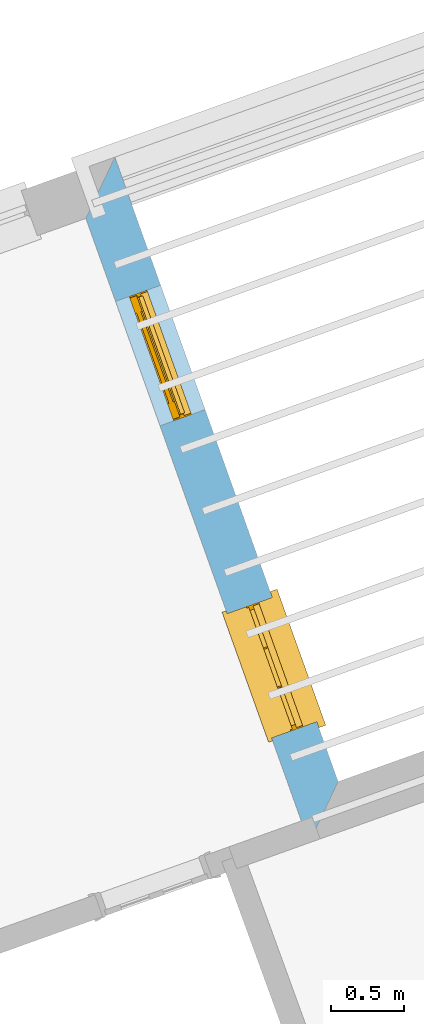
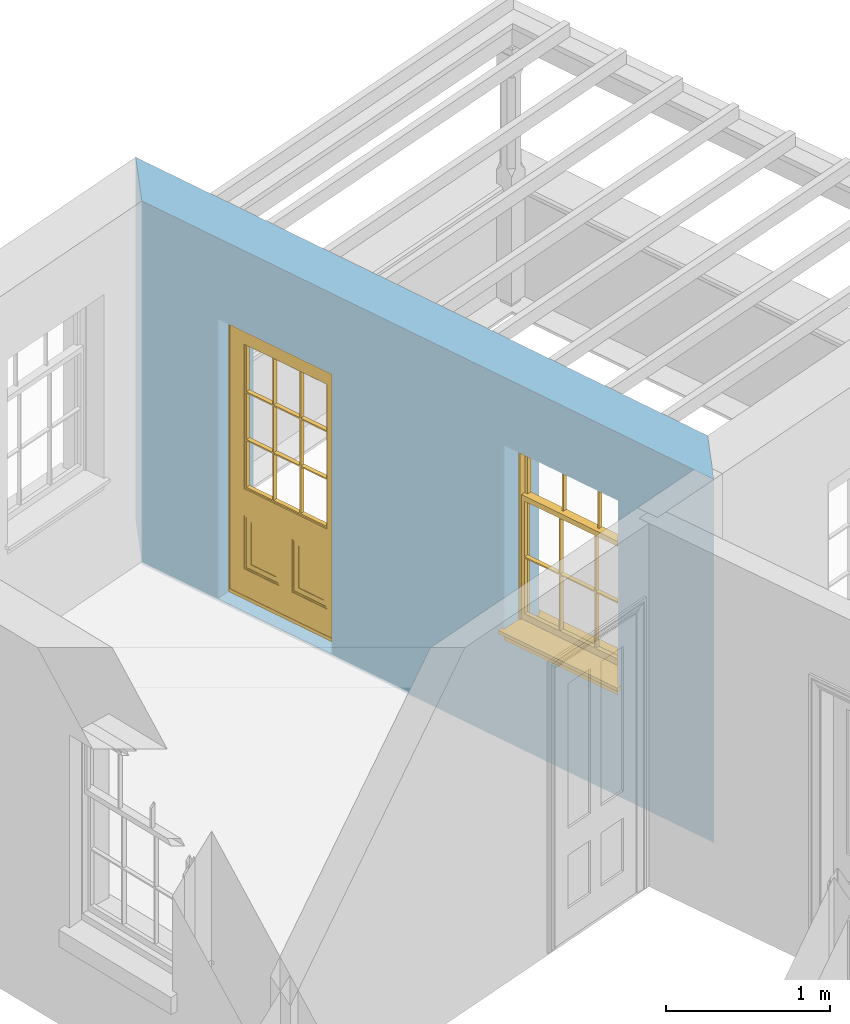
# One storey, part 9 of 12: 1 door, 1 window, 2 openings, plus 1 element that does not belong to this part.
"""IFC2X3 building model written with IfcOpenShell, lengths in metres."""

from ifc_helpers import new_model, si_unit, frame, origin, place, context, subcontext, project, spatial, polyline, outline, extrude, faceted_brep, material, layer, layer_set, layer_usage, element, fill, save


model = new_model("IFC2X3")

# Units and contexts
model_context = context("Model", 3, world=origin())
body_context = subcontext(model_context, "Body", "Model", "MODEL_VIEW")
ifc_project = project(units=[si_unit("PLANEANGLEUNIT", "RADIAN"), si_unit("MASSUNIT", "GRAM", prefix="KILO"), si_unit("FORCEUNIT", "NEWTON", prefix="KILO"), si_unit("LENGTHUNIT", "METRE")], contexts=[model_context])

# Site, building, storey
site_placement = place(None, origin())
site = spatial("IfcSite", under=ifc_project, at=site_placement, CompositionType="ELEMENT")
building_placement = place(None, origin())
building = spatial("IfcBuilding", under=site, at=building_placement, Name="Building plot-12", CompositionType="ELEMENT")
storey_placement = place(None, frame((0.0, 0.0, 6.45)))
storey = spatial("IfcBuildingStorey", under=building, at=storey_placement, Name="Floor 1", CompositionType="ELEMENT", Elevation=6.45)

# Wall, openings, window, door
ifc_material = material(Name="Masonry")
ifc_layer = layer(ifc_material, 0.33, ventilated=False)
ifc_layer_set = layer_set([ifc_layer], Name="My Wall")
ifc_layer_usage = layer_usage(ifc_layer_set, "AXIS2", "NEGATIVE", 0.08)
wall_placement = place(storey_placement, origin())
wall = element("IfcWallStandardCase", 1, at=wall_placement, inside=storey, material=ifc_layer_usage, Name="exterior", context=body_context, shape_type="SweptSolid", body=[
    extrude(outline(polyline([(57.8909410000931, 39.8252226026139), (58.0905645178046, 40.247064339734), (56.5533203704707, 44.5461889943348), (56.3536968527592, 44.1243472572147), (57.8909410000931, 39.8252226026139)])), origin(), (0.0, 0.0, 1.0), 2.7),
])
opening_1_placement = place(storey_placement, frame((0.0, 0.0, 0.75)))
opening_1 = element("IfcOpeningElement", 2, at=opening_1_placement, cuts=wall, Name="Opening", ObjectType="Opening", context=body_context, shape_type="SweptSolid", body=[
    extrude(outline(polyline([(57.9436229426122, 40.6580076175414), (57.6372311552457, 41.514876377991), (57.3264985278299, 41.4037672682867), (57.6328903151964, 40.5468985078371), (57.9436229426122, 40.6580076175414)])), origin(), (0.0, 0.0, 1.0), 1.445),
])
opening_2_placement = place(storey_placement, frame((0.0, 0.0, 0.0199999999999996)))
opening_2 = element("IfcOpeningElement", 3, at=opening_2_placement, cuts=wall, Name="Opening", ObjectType="Opening", context=body_context, shape_type="SweptSolid", body=[
    extrude(outline(polyline([(57.1750008689452, 42.8075699448418), (56.8686090815788, 43.6644387052913), (56.557876454163, 43.553329595587), (56.8642682415294, 42.6964608351374), (57.1750008689452, 42.8075699448418)])), origin(), (0.0, 0.0, 1.0), 2.08),
])
window_placement = place(storey_placement, frame((57.7082194369942, 40.5738340495836, 0.75), z_axis=(0.0, 0.0, 1.0), x_axis=(-0.306391787366465, 0.856868760449572, 0.0)))
window = element("IfcWindow", 4, at=window_placement, inside=storey, Name="bedroom outside window", OverallHeight=1.445, OverallWidth=0.91, context=body_context, shape_type="Brep", held_by="IfcProductRepresentation", body=[
    faceted_brep([(0.876875, -0.105, 0.999097), (0.876875, -0.105, 1.411875), (0.9, -0.105, 1.435), (0.033125, -0.105, 1.411875), (0.033125, -0.105, 0.999097), (0.01, -0.105, 1.435), (0.033125, -0.135, 1.411875), (0.01, -0.135, 1.435), (0.033125, -0.135, 0.999097), (0.876875, -0.135, 1.411875), (0.876875, -0.135, 0.999097), (0.9, -0.135, 1.435), (0.033125, -0.105, 0.960972), (0.01, -0.105, 0.960972), (0.033125, -0.105, 0.548195), (0.876875, -0.105, 0.960972), (0.876875, -0.105, 0.548195), (0.9, -0.105, 0.960972), (0.876875, -0.105, 0.538195), (0.876875, -0.105, 0.125417), (0.9, -0.105, 0.077167), (0.033125, -0.105, 0.125417), (0.033125, -0.105, 0.538195), (0.01, -0.105, 0.077167), (0.9, -0.135, 0.960972), (0.01, -0.135, 0.960972), (-0.0425, -0.25, 0.01), (-0.0425, -0.3, 0.001667), (0.0, -0.25, 0.01), (0.9525, -0.25, 0.01), (0.91, -0.25, 0.01), (0.9525, -0.3, 0.001667), (-0.02, 0.08, 0.077167), (0.0, 0.08, 0.077167), (-0.02, 0.11, 0.077167), (0.0, -0.06, 0.077167), (0.01, -0.06, 0.077167), (0.91, -0.06, 0.077167), (0.91, 0.08, 0.077167), (0.9, -0.06, 0.077167), (0.93, 0.08, 0.077167), (0.93, 0.11, 0.077167), (0.01, -0.105, 0.999097), (0.01, -0.075, 0.999097), (0.9, -0.105, 0.999097), (0.9, -0.075, 0.999097), (0.876875, -0.075, 0.125417), (0.876875, -0.075, 0.538195), (0.9, -0.075, 0.077167), (0.876875, -0.075, 0.548195), (0.876875, -0.075, 0.960972), (0.033125, -0.075, 0.125417), (0.01, -0.075, 0.077167), (0.033125, -0.075, 0.538195), (0.033125, -0.075, 0.960972), (0.033125, -0.075, 0.548195), (-0.02, 0.08, 0.052167), (-0.02, 0.11, 0.052167), (0.93, 0.11, 0.052167), (0.93, 0.08, 0.052167), (0.91, 0.08, 0.052167), (0.0, 0.08, 0.052167), (0.91, -0.15, 0.026667), (0.0, -0.15, 0.026667), (-0.0425, -0.3, -0.123333), (0.9525, -0.3, -0.123333), (-0.0425, -0.25, -0.123333), (0.9525, -0.25, -0.123333), (0.01, -0.06, 1.435), (0.9, -0.06, 1.435), (0.0, -0.06, 1.445), (0.91, -0.06, 1.445), (0.01, -0.15, 0.077167), (0.9, -0.15, 0.077167), (0.592292, -0.105, 0.125417), (0.592292, -0.075, 0.125417), (0.317708, -0.075, 0.125417), (0.317708, -0.105, 0.125417), (0.592292, -0.105, 0.548195), (0.317708, -0.105, 0.548195), (0.317708, -0.105, 0.538195), (0.592292, -0.105, 0.538195), (0.592292, -0.075, 0.548195), (0.317708, -0.075, 0.548195), (0.602292, -0.075, 0.548195), (0.602292, -0.105, 0.548195), (0.317708, -0.075, 0.538195), (0.307708, -0.075, 0.125417), (0.307708, -0.075, 0.538195), (0.602292, -0.075, 0.538195), (0.602292, -0.075, 0.125417), (0.592292, -0.075, 0.538195), (0.307708, -0.075, 0.548195), (0.317708, -0.075, 0.960972), (0.307708, -0.075, 0.960972), (0.602292, -0.075, 0.960972), (0.592292, -0.075, 0.960972), (0.307708, -0.105, 0.538195), (0.307708, -0.105, 0.125417), (0.307708, -0.105, 0.548195), (0.307708, -0.105, 0.960972), (0.592292, -0.105, 0.960972), (0.317708, -0.105, 0.960972), (0.602292, -0.105, 0.960972), (0.602292, -0.105, 0.538195), (0.602292, -0.105, 0.125417), (0.317708, -0.135, 1.411875), (0.307708, -0.135, 1.411875), (0.307708, -0.135, 0.999097), (0.317708, -0.135, 0.999097), (0.602292, -0.135, 1.411875), (0.592292, -0.135, 1.411875), (0.592292, -0.135, 0.999097), (0.602292, -0.135, 0.999097), (0.317708, -0.105, 0.999097), (0.307708, -0.105, 0.999097), (0.307708, -0.105, 1.411875), (0.317708, -0.105, 1.411875), (0.602292, -0.105, 0.999097), (0.592292, -0.105, 0.999097), (0.592292, -0.105, 1.411875), (0.602292, -0.105, 1.411875), (0.91, -0.15, 1.445), (0.9, -0.15, 1.435), (0.01, -0.15, 1.435), (0.0, -0.15, 1.445), (0.91, -0.25, 0.0), (0.0, -0.25, 0.0), (0.91, 0.08, 0.0), (0.0, 0.08, 0.0)], [[[0, 1, 2]], [[3, 4, 5]], [[6, 7, 8]], [[9, 10, 11]], [[12, 13, 14]], [[15, 16, 17]], [[18, 19, 20]], [[21, 22, 23]], [[24, 15, 17]], [[13, 12, 25]], [[26, 27, 28]], [[29, 30, 31]], [[32, 33, 34]], [[35, 36, 33]], [[37, 38, 39]], [[40, 41, 38]], [[42, 4, 43]], [[44, 45, 0]], [[46, 47, 48]], [[49, 50, 45]], [[51, 52, 53]], [[54, 55, 43]], [[38, 33, 36, 39]], [[41, 34, 33, 38]], [[56, 32, 34, 57]], [[57, 34, 41, 58]], [[58, 41, 40, 59]], [[57, 58, 60, 61]], [[52, 48, 39, 36]], [[62, 63, 28, 30]], [[27, 31, 30, 28]], [[27, 64, 65, 31]], [[66, 67, 65, 64]], [[2, 5, 68, 69]], [[68, 70, 71, 69]], [[20, 23, 72, 73]], [[73, 72, 63, 62]], [[74, 75, 76, 77]], [[78, 79, 80, 81]], [[78, 82, 83, 79]], [[16, 49, 84, 85]], [[86, 76, 87, 88]], [[89, 90, 75, 91]], [[92, 88, 53, 55]], [[82, 91, 86, 83]], [[93, 83, 92, 94]], [[95, 84, 82, 96]], [[89, 84, 49, 47]], [[97, 88, 87, 98]], [[22, 53, 88, 97]], [[81, 91, 75, 74]], [[80, 86, 91, 81]], [[77, 76, 86, 80]], [[99, 92, 55, 14]], [[100, 94, 92, 99]], [[101, 96, 82, 78]], [[79, 83, 93, 102]], [[85, 84, 95, 103]], [[104, 89, 47, 18]], [[105, 90, 89, 104]], [[104, 18, 16, 85]], [[80, 97, 98, 77]], [[104, 81, 74, 105]], [[103, 101, 78, 85]], [[99, 14, 22, 97]], [[102, 100, 99, 79]], [[106, 107, 108, 109]], [[110, 111, 112, 113]], [[114, 115, 116, 117]], [[118, 119, 120, 121]], [[107, 116, 115, 108]], [[111, 120, 119, 112]], [[109, 114, 117, 106]], [[113, 118, 121, 110]], [[85, 78, 81, 104]], [[84, 89, 91, 82]], [[83, 86, 88, 92]], [[79, 99, 97, 80]], [[109, 112, 119, 114]], [[102, 93, 96, 101]], [[106, 117, 120, 111]], [[98, 87, 51, 21]], [[6, 3, 116, 107]], [[110, 121, 1, 9]], [[19, 46, 90, 105]], [[26, 66, 64, 27]], [[29, 31, 65, 67]], [[25, 24, 112, 109]], [[11, 7, 106, 111]], [[75, 48, 52, 76]], [[43, 45, 96, 93]], [[45, 43, 114, 119]], [[5, 2, 120, 117]], [[24, 25, 102, 101]], [[42, 5, 4]], [[2, 44, 0]], [[49, 45, 48, 47]], [[52, 43, 55, 53]], [[14, 13, 23, 22]], [[20, 17, 16, 18]], [[24, 11, 10]], [[25, 8, 7]], [[8, 4, 3, 6]], [[9, 1, 0, 10]], [[15, 50, 49, 16]], [[18, 47, 46, 19]], [[21, 51, 53, 22]], [[14, 55, 54, 12]], [[44, 2, 69, 45]], [[68, 5, 42, 43]], [[36, 35, 70, 68]], [[39, 69, 71, 37]], [[62, 122, 123, 73]], [[63, 72, 124, 125]], [[8, 108, 115, 4]], [[113, 10, 0, 118]], [[94, 100, 12, 54]], [[17, 20, 73, 24]], [[72, 23, 13, 25]], [[52, 36, 68, 43]], [[69, 39, 48, 45]], [[11, 24, 73, 123]], [[7, 124, 72, 25]], [[23, 77, 98]], [[98, 21, 23]], [[105, 74, 20]], [[20, 19, 105]], [[20, 74, 77, 23]], [[113, 112, 24]], [[24, 10, 113]], [[25, 109, 108]], [[108, 8, 25]], [[110, 9, 11]], [[11, 111, 110]], [[7, 6, 107]], [[107, 106, 7]], [[5, 117, 116]], [[116, 3, 5]], [[121, 120, 2]], [[2, 1, 121]], [[11, 123, 124, 7]], [[122, 125, 124, 123]], [[43, 93, 94]], [[94, 54, 43]], [[96, 45, 95]], [[50, 95, 45]], [[15, 103, 95, 50]], [[48, 75, 90]], [[90, 46, 48]], [[87, 76, 52]], [[52, 51, 87]], [[103, 15, 24]], [[24, 101, 103]], [[100, 102, 25]], [[25, 12, 100]], [[115, 114, 43]], [[43, 4, 115]], [[118, 0, 45]], [[45, 119, 118]], [[71, 70, 125, 122]], [[70, 35, 63, 125]], [[122, 62, 37, 71]], [[126, 67, 66, 127]], [[60, 58, 59]], [[38, 60, 59, 40]], [[61, 56, 57]], [[32, 56, 61, 33]], [[61, 60, 128, 129]], [[62, 60, 38, 37]], [[126, 128, 60, 62]], [[33, 61, 63, 35]], [[61, 129, 127, 63]], [[128, 126, 127, 129]], [[28, 127, 66, 26]], [[63, 127, 28]], [[29, 67, 126, 30]], [[30, 126, 62]]]),
])
fill(opening_1, window)
door_placement = place(storey_placement, frame((56.9395973633272, 42.7233963768839, 0.0199999999999996), z_axis=(0.0, 0.0, 1.0), x_axis=(-0.306391787366465, 0.856868760449572, 0.0)))
door = element("IfcDoor", 5, at=door_placement, inside=storey, Name="bedroom outside door", OverallHeight=2.08, OverallWidth=0.91, context=body_context, shape_type="Brep", held_by="IfcProductRepresentation", body=[
    faceted_brep([(0.545, -0.055, 0.265), (0.745, -0.055, 0.265), (0.745, -0.05, 0.265), (0.545, -0.05, 0.265), (0.745, -0.05, 0.58), (0.545, -0.05, 0.58), (0.545, -0.055, 0.58), (0.515, -0.06, 0.235), (0.775, -0.06, 0.235), (0.745, -0.055, 0.58), (0.515, -0.06, 0.61), (0.515, -0.065, 0.235), (0.775, -0.065, 0.235), (0.775, -0.06, 0.61), (0.515, -0.065, 0.61), (0.785, -0.065, 0.225), (0.505, -0.065, 0.225), (0.775, -0.065, 0.61), (0.505, -0.065, 0.62), (0.785, -0.065, 0.62), (0.505, -0.07, 0.225), (0.785, -0.07, 0.225), (0.505, -0.07, 0.62), (0.785, -0.07, 0.62), (0.883, -0.07, 0.075), (0.898, -0.07, 0.075), (0.405, -0.07, 0.62), (0.405, -0.07, 0.225), (0.027, -0.07, 0.075), (0.785, -0.07, 0.82), (0.125, -0.07, 0.82), (0.405, -0.065, 0.62), (0.405, -0.065, 0.225), (0.898, -0.07, 2.068), (0.027, -0.08, 0.075), (0.883, -0.08, 0.075), (0.125, -0.07, 0.225), (0.012, -0.07, 0.075), (0.785, -0.06, 0.82), (0.125, -0.06, 0.82), (0.125, -0.07, 0.62), (0.125, -0.065, 0.62), (0.395, -0.065, 0.61), (0.395, -0.065, 0.235), (0.125, -0.065, 0.225), (0.785, -0.07, 1.895), (0.027, -0.11, 0.045), (0.883, -0.11, 0.045), (0.558333, -0.06, 0.83), (0.351667, -0.06, 0.83), (0.125, -0.07, 1.895), (0.125, -0.06, 1.895), (0.785, -0.06, 1.895), (0.012, -0.07, 2.068), (0.135, -0.065, 0.61), (0.395, -0.06, 0.61), (0.395, -0.06, 0.235), (0.135, -0.065, 0.235), (0.027, -0.11, 0.027), (0.883, -0.11, 0.027), (0.568333, -0.06, 0.83), (0.558333, -0.03, 0.83), (0.351667, -0.03, 0.83), (0.341667, -0.06, 0.83), (0.135, -0.06, 1.185), (0.135, -0.06, 1.53), (0.775, -0.06, 1.53), (0.775, -0.06, 1.185), (0.135, -0.06, 0.61), (0.365, -0.055, 0.58), (0.365, -0.055, 0.265), (0.135, -0.06, 0.235), (0.568333, -0.06, 1.175), (0.558333, -0.06, 1.175), (0.775, -0.06, 0.83), (0.558333, -0.03, 1.175), (0.785, -0.03, 0.82), (0.125, -0.03, 0.82), (0.351667, -0.03, 1.175), (0.351667, -0.06, 1.175), (0.341667, -0.06, 1.175), (0.135, -0.06, 0.83), (0.135, -0.06, 1.175), (0.135, -0.03, 1.185), (0.135, -0.03, 1.53), (0.135, -0.06, 1.54), (0.351667, -0.06, 1.885), (0.558333, -0.06, 1.885), (0.775, -0.03, 1.53), (0.775, -0.03, 1.185), (0.775, -0.06, 1.175), (0.775, -0.06, 1.54), (0.165, -0.055, 0.58), (0.365, -0.05, 0.58), (0.365, -0.05, 0.265), (0.165, -0.055, 0.265), (0.568333, -0.03, 0.83), (0.568333, -0.03, 1.175), (0.568333, -0.06, 1.185), (0.558333, -0.06, 1.185), (0.775, -0.03, 0.83), (0.785, -0.02, 0.82), (0.125, -0.02, 0.82), (0.341667, -0.03, 0.83), (0.341667, -0.03, 1.175), (0.351667, -0.06, 1.185), (0.341667, -0.06, 1.185), (0.135, -0.03, 0.83), (0.341667, -0.03, 1.185), (0.125, -0.03, 1.895), (0.341667, -0.03, 1.53), (0.341667, -0.06, 1.53), (0.135, -0.06, 1.885), (0.341667, -0.06, 1.54), (0.341667, -0.06, 1.885), (0.558333, -0.03, 1.885), (0.351667, -0.03, 1.885), (0.568333, -0.06, 1.885), (0.785, -0.03, 1.895), (0.568333, -0.03, 1.185), (0.568333, -0.06, 1.53), (0.568333, -0.03, 1.53), (0.568333, -0.06, 1.54), (0.775, -0.06, 1.885), (0.165, -0.05, 0.58), (0.165, -0.05, 0.265), (0.775, -0.03, 1.175), (0.558333, -0.06, 1.53), (0.351667, -0.03, 1.185), (0.558333, -0.03, 1.185), (0.505, -0.02, 0.62), (0.405, -0.02, 0.62), (0.125, -0.02, 1.895), (0.785, -0.02, 1.895), (0.351667, -0.06, 1.53), (0.135, -0.03, 1.175), (0.135, -0.03, 1.54), (0.341667, -0.03, 1.54), (0.135, -0.03, 1.885), (0.351667, -0.06, 1.54), (0.558333, -0.03, 1.54), (0.558333, -0.06, 1.54), (0.351667, -0.03, 1.54), (0.775, -0.03, 1.54), (0.568333, -0.03, 1.54), (0.775, -0.03, 1.885), (0.558333, -0.03, 1.53), (0.405, -0.02, 0.225), (0.505, -0.02, 0.225), (0.125, -0.02, 0.62), (0.785, -0.02, 0.62), (0.012, -0.02, 2.068), (0.898, -0.02, 2.068), (0.351667, -0.03, 1.53), (0.341667, -0.03, 1.885), (0.568333, -0.03, 1.885), (0.405, -0.025, 0.225), (0.405, -0.025, 0.62), (0.505, -0.025, 0.62), (0.505, -0.025, 0.225), (0.898, -0.02, 0.027), (0.012, -0.02, 0.027), (0.125, -0.025, 0.62), (0.785, -0.025, 0.62), (0.395, -0.025, 0.235), (0.395, -0.025, 0.61), (0.125, -0.02, 0.225), (0.125, -0.025, 0.225), (0.515, -0.025, 0.61), (0.515, -0.025, 0.235), (0.785, -0.02, 0.225), (0.785, -0.025, 0.225), (0.135, -0.025, 0.61), (0.775, -0.025, 0.61), (0.135, -0.025, 0.235), (0.395, -0.03, 0.235), (0.395, -0.03, 0.61), (0.515, -0.03, 0.61), (0.515, -0.03, 0.235), (0.775, -0.025, 0.235), (0.135, -0.03, 0.61), (0.775, -0.03, 0.61), (0.135, -0.03, 0.235), (0.365, -0.035, 0.265), (0.365, -0.035, 0.58), (0.545, -0.035, 0.58), (0.545, -0.035, 0.265), (0.775, -0.03, 0.235), (0.165, -0.035, 0.58), (0.745, -0.035, 0.58), (0.165, -0.035, 0.265), (0.365, -0.04, 0.58), (0.365, -0.04, 0.265), (0.545, -0.04, 0.58), (0.545, -0.04, 0.265), (0.745, -0.035, 0.265), (0.165, -0.04, 0.58), (0.745, -0.04, 0.58), (0.165, -0.04, 0.265), (0.745, -0.04, 0.265), (0.885, -0.072, 0.025), (0.025, -0.072, 0.025), (0.025, -0.1, 0.025), (0.885, -0.1, 0.025), (0.9, -0.02, 0.025), (0.01, -0.02, 0.025), (0.9, -0.072, 0.025), (0.91, -0.02, 0.0), (0.0, -0.02, 0.0), (0.01, -0.072, 0.025), (0.9, -0.072, 2.07), (0.9, -0.02, 2.07), (0.885, -0.072, 2.055), (0.91, -0.02, 2.08), (0.01, -0.02, 2.07), (0.0, -0.02, 2.08), (0.01, -0.072, 2.07), (0.025, -0.072, 2.055), (0.0, -0.15, 2.08), (0.91, -0.15, 2.08), (0.01, -0.15, 2.07), (0.9, -0.15, 2.07), (0.01, -0.1, 2.07), (0.9, -0.1, 2.07), (0.0, -0.15, 0.0), (0.91, -0.15, 0.0), (0.01, -0.15, 0.025), (0.9, -0.15, 0.025), (0.01, -0.1, 0.025), (0.025, -0.1, 2.055), (0.9, -0.1, 0.025), (0.885, -0.1, 2.055), (0.898, -0.07, 0.027), (0.012, -0.07, 0.027), (0.883, -0.07, 0.027), (0.027, -0.07, 0.027)], [[[0, 1, 2, 3]], [[2, 4, 5, 3]], [[0, 3, 5, 6]], [[1, 0, 7, 8]], [[9, 4, 2, 1]], [[9, 6, 5, 4]], [[0, 6, 10, 7]], [[8, 7, 11, 12]], [[8, 13, 9, 1]], [[13, 10, 6, 9]], [[7, 10, 14, 11]], [[15, 12, 11, 16]], [[12, 17, 13, 8]], [[17, 14, 10, 13]], [[18, 16, 11, 14]], [[15, 19, 17, 12]], [[15, 16, 20, 21]], [[14, 17, 19, 18]], [[16, 18, 22, 20]], [[21, 23, 19, 15]], [[24, 25, 21, 20]], [[23, 22, 18, 19]], [[20, 22, 26, 27]], [[23, 21, 25]], [[28, 24, 20, 27]], [[22, 23, 29]], [[29, 30, 26, 22]], [[27, 26, 31, 32]], [[23, 25, 33, 29]], [[34, 35, 24, 28]], [[28, 27, 36, 37]], [[38, 39, 30, 29]], [[26, 30, 40]], [[26, 40, 41, 31]], [[42, 43, 32, 31]], [[32, 44, 36, 27]], [[33, 45, 29]], [[46, 47, 35, 34]], [[36, 40, 37]], [[39, 38, 48, 49]], [[50, 30, 39, 51]], [[29, 45, 52, 38]], [[53, 37, 40, 30]], [[44, 41, 40, 36]], [[31, 41, 54, 42]], [[43, 42, 55, 56]], [[57, 44, 32, 43]], [[50, 45, 33, 53]], [[47, 46, 58, 59]], [[60, 48, 38]], [[49, 48, 61, 62]], [[49, 63, 39]], [[50, 53, 30]], [[51, 39, 64, 65]], [[45, 50, 51, 52]], [[66, 67, 38, 52]], [[57, 54, 41, 44]], [[42, 54, 68, 55]], [[56, 55, 69, 70]], [[56, 71, 57, 43]], [[60, 72, 73, 48]], [[60, 38, 74]], [[48, 73, 75, 61]], [[76, 77, 62, 61]], [[62, 78, 79, 49]], [[49, 79, 80, 63]], [[63, 81, 39]], [[82, 64, 39]], [[65, 64, 83, 84]], [[85, 51, 65]], [[52, 51, 86, 87]], [[88, 89, 67, 66]], [[90, 38, 67]], [[91, 66, 52]], [[71, 68, 54, 57]], [[55, 68, 92, 69]], [[69, 93, 94, 70]], [[70, 95, 71, 56]], [[96, 97, 72, 60]], [[73, 72, 98, 99]], [[74, 38, 90]], [[100, 96, 60, 74]], [[75, 73, 79, 78]], [[61, 75, 97, 96]], [[101, 102, 77, 76]], [[77, 103, 62]], [[96, 76, 61]], [[103, 104, 78, 62]], [[80, 79, 105, 106]], [[63, 80, 104, 103]], [[81, 63, 103, 107]], [[81, 82, 39]], [[106, 64, 82, 80]], [[106, 108, 83, 64]], [[84, 83, 77, 109]], [[110, 111, 65, 84]], [[112, 51, 85]], [[113, 85, 65, 111]], [[114, 86, 51]], [[115, 87, 86, 116]], [[117, 52, 87]], [[118, 76, 89, 88]], [[119, 98, 67, 89]], [[120, 121, 88, 66]], [[67, 98, 72, 90]], [[91, 122, 120, 66]], [[91, 52, 123]], [[95, 92, 68, 71]], [[69, 92, 124, 93]], [[94, 93, 124, 125]], [[94, 125, 95, 70]], [[72, 97, 126, 90]], [[127, 99, 98, 120]], [[99, 105, 79, 73]], [[74, 90, 126, 100]], [[96, 100, 76]], [[128, 129, 75, 78]], [[97, 75, 129, 119]], [[130, 131, 102, 101]], [[109, 77, 102, 132]], [[133, 101, 76, 118]], [[77, 107, 103]], [[78, 104, 108, 128]], [[111, 106, 105, 134]], [[104, 80, 82, 135]], [[107, 135, 82, 81]], [[110, 108, 106, 111]], [[104, 135, 83, 108]], [[83, 135, 77]], [[136, 84, 109]], [[110, 84, 136, 137]], [[114, 51, 112]], [[85, 136, 138, 112]], [[113, 137, 136, 85]], [[111, 134, 139, 113]], [[86, 114, 113, 139]], [[140, 141, 87, 115]], [[139, 142, 116, 86]], [[109, 118, 115, 116]], [[117, 123, 52]], [[117, 87, 141, 122]], [[126, 89, 76]], [[143, 118, 88]], [[120, 98, 119, 121]], [[119, 89, 126, 97]], [[144, 143, 88, 121]], [[144, 122, 91, 143]], [[127, 120, 122, 141]], [[143, 91, 123, 145]], [[124, 92, 95, 125]], [[146, 129, 99, 127]], [[99, 129, 128, 105]], [[100, 126, 76]], [[121, 119, 129, 146]], [[147, 131, 130, 148]], [[131, 149, 102]], [[130, 101, 150]], [[102, 151, 132]], [[118, 109, 132, 133]], [[101, 133, 152]], [[107, 77, 135]], [[153, 128, 108, 110]], [[134, 105, 128, 153]], [[109, 138, 136]], [[153, 110, 137, 142]], [[154, 114, 112, 138]], [[137, 113, 114, 154]], [[141, 139, 134, 127]], [[141, 140, 142, 139]], [[144, 140, 115, 155]], [[142, 137, 154, 116]], [[155, 115, 118]], [[116, 154, 109]], [[117, 155, 145, 123]], [[122, 144, 155, 117]], [[143, 145, 118]], [[121, 146, 140, 144]], [[146, 127, 134, 153]], [[156, 157, 131, 147]], [[148, 130, 158, 159]], [[148, 160, 161, 147]], [[157, 162, 149, 131]], [[161, 151, 102, 149]], [[101, 152, 160, 150]], [[163, 158, 130, 150]], [[151, 152, 133, 132]], [[154, 138, 109]], [[142, 140, 146, 153]], [[145, 155, 118]], [[157, 156, 164, 165]], [[147, 166, 167, 156]], [[168, 169, 159, 158]], [[170, 148, 159, 171]], [[148, 170, 160]], [[166, 147, 161]], [[172, 162, 157, 165]], [[166, 149, 162, 167]], [[166, 161, 149]], [[150, 160, 170]], [[163, 173, 168, 158]], [[171, 163, 150, 170]], [[174, 164, 156, 167]], [[175, 176, 165, 164]], [[169, 168, 177, 178]], [[171, 159, 169, 179]], [[167, 162, 172, 174]], [[176, 180, 172, 165]], [[179, 173, 163, 171]], [[181, 177, 168, 173]], [[164, 174, 182, 175]], [[183, 184, 176, 175]], [[178, 177, 185, 186]], [[179, 169, 178, 187]], [[174, 172, 180, 182]], [[184, 188, 180, 176]], [[187, 181, 173, 179]], [[189, 185, 177, 181]], [[175, 182, 190, 183]], [[191, 184, 183, 192]], [[185, 193, 194, 186]], [[187, 178, 186, 195]], [[182, 180, 188, 190]], [[191, 196, 188, 184]], [[195, 189, 181, 187]], [[197, 193, 185, 189]], [[183, 190, 198, 192]], [[198, 196, 191, 192]], [[194, 193, 197, 199]], [[195, 186, 194, 199]], [[188, 196, 198, 190]], [[197, 189, 195, 199]], [[200, 201, 202, 203]], [[201, 200, 204, 205]], [[206, 204, 200]], [[204, 207, 208, 205]], [[209, 201, 205]], [[210, 211, 204, 206]], [[206, 200, 212, 210]], [[211, 213, 207, 204]], [[214, 205, 208, 215]], [[216, 217, 201, 209]], [[205, 214, 216, 209]], [[216, 214, 211, 210]], [[210, 212, 217, 216]], [[214, 215, 213, 211]], [[218, 219, 213, 215]], [[219, 218, 220, 221]], [[221, 220, 222, 223]], [[215, 208, 224, 218]], [[225, 224, 208, 207]], [[224, 226, 220, 218]], [[224, 225, 227, 226]], [[219, 225, 207, 213]], [[228, 222, 220, 226]], [[219, 221, 227, 225]], [[226, 227, 203, 202]], [[202, 229, 222, 228]], [[228, 226, 202]], [[227, 221, 223, 230]], [[230, 203, 227]], [[217, 229, 202, 201]], [[231, 223, 222, 229]], [[230, 223, 231, 203]], [[231, 229, 217, 212]], [[212, 200, 203, 231]], [[33, 152, 151, 53]], [[25, 160, 152, 33]], [[161, 37, 53, 151]], [[232, 160, 25]], [[161, 233, 37]], [[160, 232, 234]], [[24, 234, 232, 25]], [[233, 161, 235]], [[37, 233, 235, 28]], [[161, 160, 234, 235]], [[35, 47, 234, 24]], [[28, 235, 46, 34]], [[58, 235, 234, 59]], [[59, 234, 47]], [[58, 46, 235]]]),
])
fill(opening_2, door)

save(model, "model.ifc")
